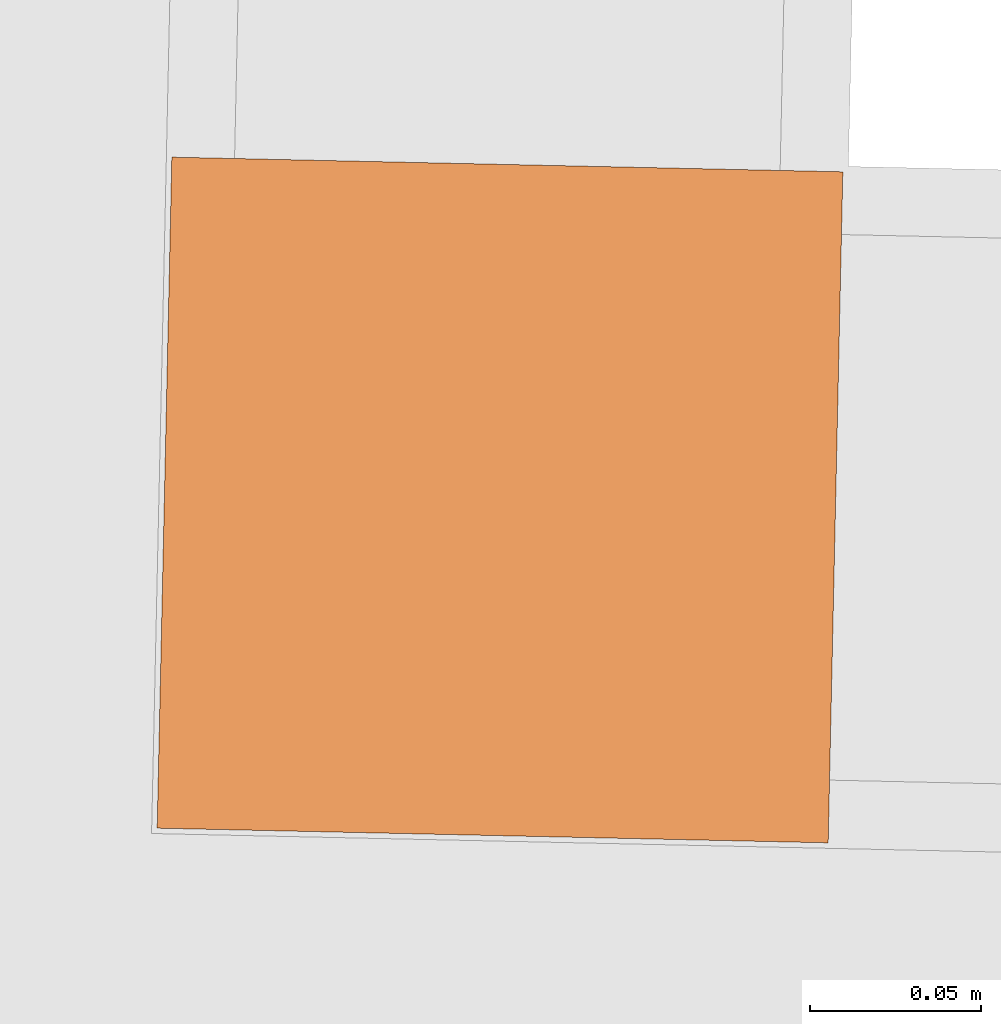
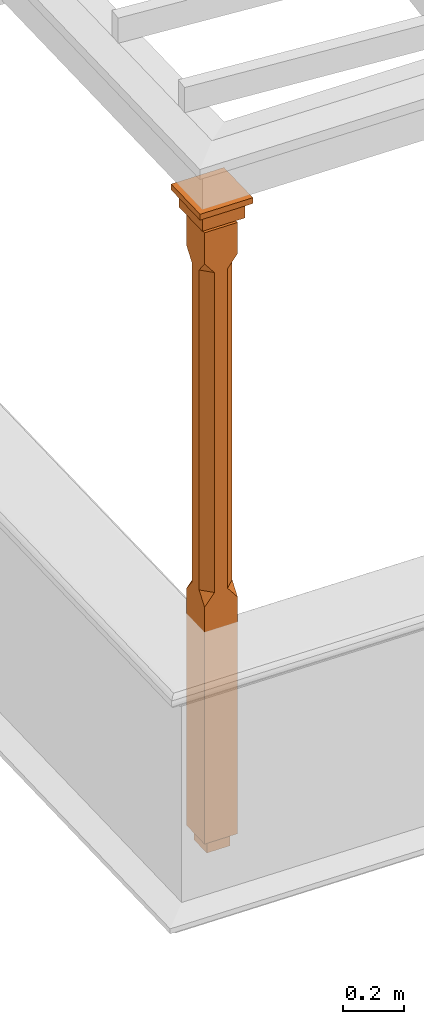
# One storey, part 12 of 12: 1 proxy.
"""IFC2X3 building model written with IfcOpenShell, lengths in metres."""

from ifc_helpers import new_model, si_unit, frame, origin, place, context, subcontext, project, spatial, faceted_brep, element, save


model = new_model("IFC2X3")

# Units and contexts
model_context = context("Model", 3, world=origin())
body_context = subcontext(model_context, "Body", "Model", "MODEL_VIEW")
ifc_project = project(units=[si_unit("PLANEANGLEUNIT", "RADIAN"), si_unit("MASSUNIT", "GRAM", prefix="KILO"), si_unit("FORCEUNIT", "NEWTON", prefix="KILO"), si_unit("LENGTHUNIT", "METRE")], contexts=[model_context])

# Site, building, storey
site_placement = place(None, origin())
site = spatial("IfcSite", under=ifc_project, at=site_placement, CompositionType="ELEMENT")
building_placement = place(None, origin())
building = spatial("IfcBuilding", under=site, at=building_placement, Name="Building plot-18", CompositionType="ELEMENT")
storey_placement = place(None, frame((0.0, 0.0, 6.6)))
storey = spatial("IfcBuildingStorey", under=building, at=storey_placement, Name="Floor 1", CompositionType="ELEMENT", Elevation=6.6)

# Proxy
proxy_placement = place(storey_placement, frame((93.8532821448265, 16.875659930283, 0.0), z_axis=(0.0, 0.0, 1.0), x_axis=(0.999760886959149, -0.0218670735732066, 0.0)))
element("IfcBuildingElementProxy", 1, at=proxy_placement, inside=storey, Name="pergola post", CompositionType="ELEMENT", context=body_context, shape_type="Brep", held_by="IfcProductRepresentation", body=[
    faceted_brep([(0.0246, -0.0615, 2.32), (0.0615, -0.0246, 2.32), (0.0615, -0.0615, 2.366667), (0.0615, -0.0246, 1.044444), (0.0246, -0.0615, 1.044444), (0.0615, 0.0246, 2.32), (0.0615, 0.0615, 2.366667), (-0.0246, -0.0615, 2.32), (-0.0615, -0.0615, 2.366667), (-0.0246, -0.0615, 1.044444), (0.0615, -0.0615, 0.997778), (0.0615, 0.0246, 1.044444), (0.0246, 0.0615, 2.32), (0.0615, 0.0615, 2.491111), (0.0615, -0.0615, 2.491111), (-0.0615, -0.0615, 2.491111), (-0.0615, -0.0246, 2.32), (-0.0615, -0.0246, 1.044444), (-0.0615, -0.0615, 0.997778), (0.0615, 0.0615, 0.997778), (0.0246, 0.0615, 1.044444), (-0.0246, 0.0615, 2.32), (-0.0615, 0.0615, 2.366667), (0.04305, 0.04305, 2.491111), (0.04305, -0.04305, 2.491111), (-0.0615, 0.0615, 2.491111), (-0.04305, -0.04305, 2.491111), (-0.0615, 0.0246, 2.32), (-0.0615, 0.0246, 1.044444), (0.0615, -0.0615, 0.053333), (-0.0615, -0.0615, 0.053333), (0.0615, 0.0615, 0.053333), (-0.0246, 0.0615, 1.044444), (-0.04305, 0.04305, 2.491111), (0.04305, 0.04305, 2.514444), (0.04305, -0.04305, 2.514444), (-0.04305, -0.04305, 2.514444), (-0.0615, 0.0615, 0.997778), (-0.0615, 0.0615, 0.053333), (-0.04305, -0.04305, 0.053333), (0.04305, -0.04305, 0.053333), (0.04305, 0.04305, 0.053333), (-0.04305, 0.04305, 2.514444), (0.07995, 0.07995, 2.514444), (0.07995, -0.07995, 2.514444), (-0.07995, -0.07995, 2.514444), (-0.04305, 0.04305, 0.053333), (-0.04305, -0.04305, 0.0), (0.04305, -0.04305, 0.0), (0.04305, 0.04305, 0.0), (-0.07995, 0.07995, 2.514444), (0.07995, 0.07995, 2.576667), (0.07995, -0.07995, 2.576667), (-0.07995, -0.07995, 2.576667), (-0.04305, 0.04305, 0.0), (-0.07995, 0.07995, 2.576667), (0.0984, 0.0984, 2.576667), (0.0984, -0.0984, 2.576667), (-0.0984, -0.0984, 2.576667), (-0.0984, 0.0984, 2.576667), (0.0984, 0.0984, 2.6), (0.0984, -0.0984, 2.6), (-0.0984, -0.0984, 2.6), (-0.0984, 0.0984, 2.6)], [[[0, 1, 2]], [[3, 1, 0, 4]], [[1, 5, 6, 2]], [[7, 0, 2, 8]], [[4, 0, 7, 9]], [[3, 4, 10]], [[1, 3, 11, 5]], [[5, 12, 6]], [[13, 14, 2, 6]], [[15, 8, 2, 14]], [[8, 16, 7]], [[9, 7, 16, 17]], [[9, 18, 10, 4]], [[3, 10, 19, 11]], [[20, 12, 5, 11]], [[21, 22, 6, 12]], [[14, 13, 23, 24]], [[13, 6, 22, 25]], [[25, 22, 8, 15]], [[26, 15, 14, 24]], [[16, 8, 22, 27]], [[27, 28, 17, 16]], [[17, 18, 9]], [[29, 10, 18, 30]], [[31, 19, 10, 29]], [[20, 11, 19]], [[12, 20, 32, 21]], [[21, 27, 22]], [[33, 23, 13, 25]], [[23, 34, 35, 24]], [[26, 33, 25, 15]], [[36, 26, 24, 35]], [[28, 27, 21, 32]], [[17, 28, 37, 18]], [[38, 30, 18, 37]], [[29, 30, 39, 40]], [[31, 38, 37, 19]], [[40, 41, 31, 29]], [[32, 20, 19, 37]], [[33, 42, 34, 23]], [[43, 44, 35, 34]], [[42, 33, 26, 36]], [[36, 35, 44, 45]], [[28, 32, 37]], [[46, 39, 30, 38]], [[39, 47, 48, 40]], [[46, 38, 31, 41]], [[49, 41, 40, 48]], [[43, 34, 42, 50]], [[43, 51, 52, 44]], [[45, 50, 42, 36]], [[53, 45, 44, 52]], [[46, 54, 47, 39]], [[54, 46, 41, 49]], [[50, 55, 51, 43]], [[56, 57, 52, 51]], [[55, 50, 45, 53]], [[53, 52, 57, 58]], [[56, 51, 55, 59]], [[56, 60, 61, 57]], [[58, 59, 55, 53]], [[62, 58, 57, 61]], [[59, 63, 60, 56]], [[63, 62, 61, 60]], [[58, 62, 63, 59]], [[47, 54, 49, 48]]]),
])

save(model, "model.ifc")
